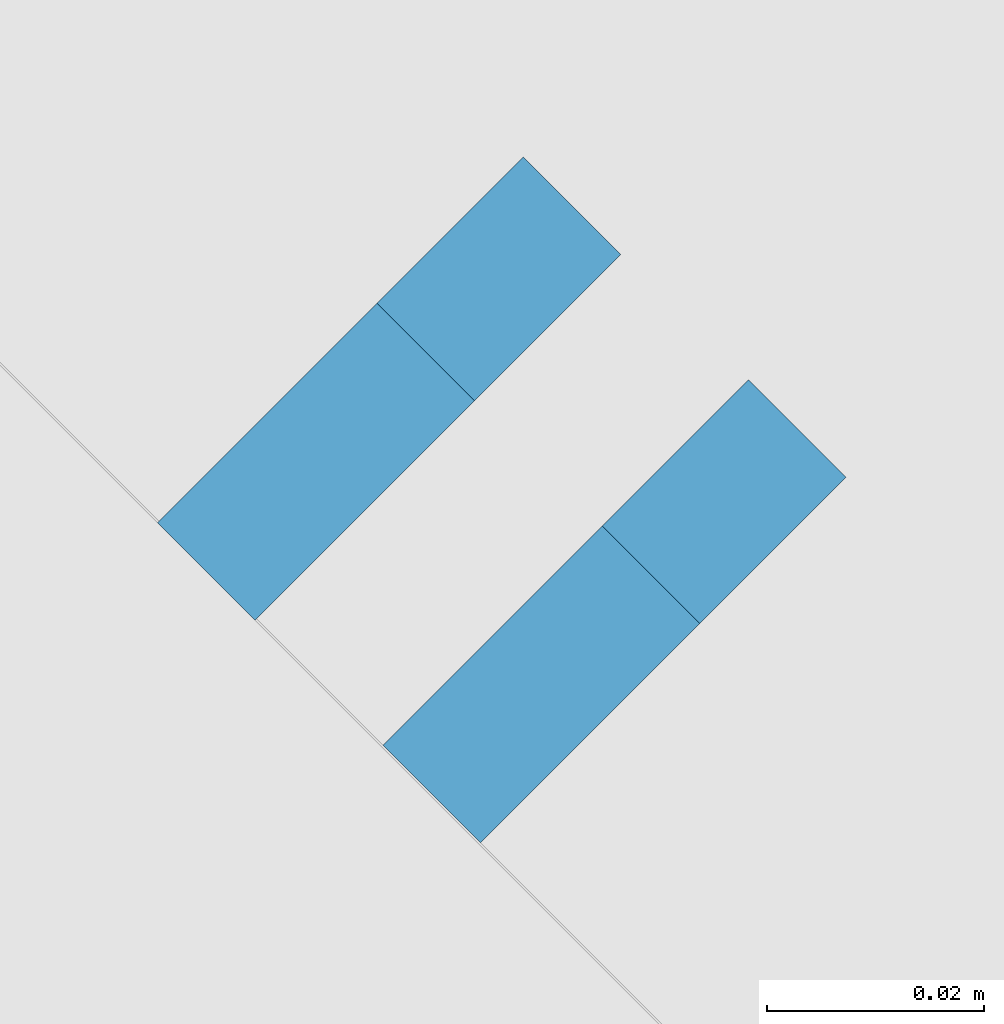
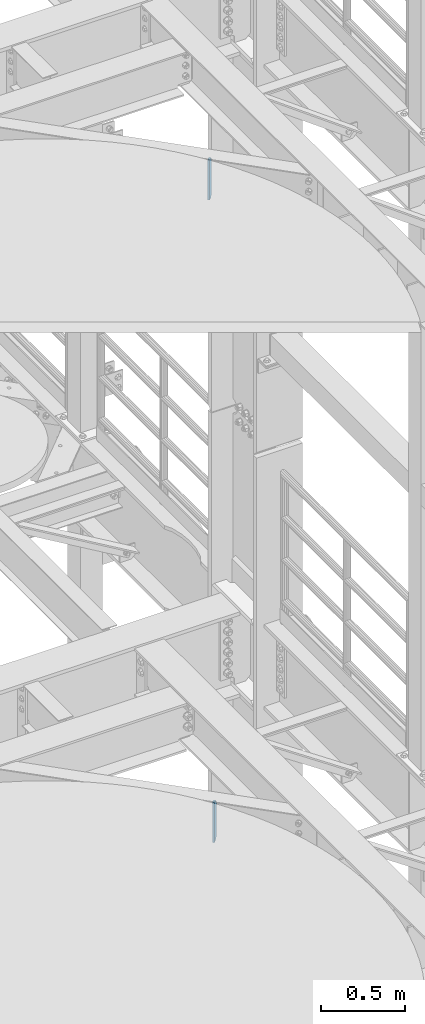
# One storey, part 1568 of 1876: 2 plates, 2 elements without a shape of their own.
"""IFC2X3 building model written with IfcOpenShell, lengths in millimetres."""

from ifc_helpers import new_model, si_unit, frame, origin_with_axes, place, context, subcontext, project, spatial, faceted_brep, material, type_object, element, aggregate, save


model = new_model("IFC2X3")

# Units and contexts
model_context = context("Model", 3, precision=1e-05, world=origin_with_axes())
body_context = subcontext(model_context, "Body", "Model", "MODEL_VIEW")
ifc_project = project(units=[si_unit("LENGTHUNIT", "METRE", prefix="MILLI"), si_unit("AREAUNIT", "SQUARE_METRE"), si_unit("VOLUMEUNIT", "CUBIC_METRE"), si_unit("MASSUNIT", "GRAM", prefix="KILO"), si_unit("TIMEUNIT", "SECOND"), si_unit("PLANEANGLEUNIT", "RADIAN"), si_unit("SOLIDANGLEUNIT", "STERADIAN"), si_unit("THERMODYNAMICTEMPERATUREUNIT", "DEGREE_CELSIUS"), si_unit("LUMINOUSINTENSITYUNIT", "LUMEN")], contexts=[model_context])

# Site, building, storey
site_placement = place(None, origin_with_axes())
site = spatial("IfcSite", under=ifc_project, at=site_placement, CompositionType="ELEMENT")
building_placement = place(site_placement, origin_with_axes())
building = spatial("IfcBuilding", under=site, at=building_placement, Name="Undefined", CompositionType="ELEMENT")
storey_placement = place(building_placement, origin_with_axes())
storey = spatial("IfcBuildingStorey", under=building, at=storey_placement, Name="Undefined", CompositionType="ELEMENT", Elevation=0.0)

# Assembly, plate
assembly_1_placement = place(storey_placement, origin_with_axes())
assembly_1 = element("IfcElementAssembly", 1, at=assembly_1_placement, inside=storey, Name="BEAM", AssemblyPlace="NOTDEFINED", PredefinedType="RIGID_FRAME")
ifc_material = material(Name="STEEL/A36")
plate_type = type_object("IfcPlateType", PredefinedType="NOTDEFINED")
plate_1_placement = place(assembly_1_placement, frame((6301.28054878455, -201.180674335236, 17684.75), z_axis=(0.0, 0.0, 1.0), x_axis=(0.707106781186548, 0.707106781186547, 0.0)))
plate_1 = element("IfcPlate", 2, at=plate_1_placement, type_object=plate_type, material=ifc_material, Name="PLATE", context=body_context, shape_type="Brep", body=[
    faceted_brep([(0.0, -6.35000000000036, 0.0), (-1.13686837721616e-12, -6.35000000000082, 292.100006103516), (1.13686837721616e-12, 6.35000000000105, 292.100006103516), (0.0, 6.35000000000036, 0.0), (28.5750007629385, -6.35000000000014, 292.100006103516), (28.5750007629406, 6.35000000000173, 292.100006103516), (47.6249999999993, -6.34999999999968, 273.050006866455), (47.6250000000014, 6.35000000000218, 273.050006866455), (47.6249999999993, -6.34999999999968, 19.0499992370605), (47.6250000000014, 6.35000000000218, 19.0499992370605), (28.5750007629385, -6.35000000000014, 0.0), (28.5750007629406, 6.35000000000173, 0.0)], [[[0, 1, 2, 3]], [[1, 4, 5, 2]], [[4, 6, 7, 5]], [[6, 8, 9, 7]], [[8, 10, 11, 9]], [[10, 0, 3, 11]], [[5, 7, 9, 11, 3, 2]], [[10, 8, 6, 4, 1, 0]]]),
])
aggregate(assembly_1, [plate_1])

assembly_2_placement = place(storey_placement, origin_with_axes())
assembly_2 = element("IfcElementAssembly", 3, at=assembly_2_placement, inside=storey, Name="BEAM", AssemblyPlace="NOTDEFINED", PredefinedType="RIGID_FRAME")
plate_2_placement = place(assembly_2_placement, frame((6322.0458182018, -221.690383706047, 13011.15), z_axis=(0.0, 0.0, 1.0), x_axis=(0.707106781186548, 0.707106781186547, 0.0)))
plate_2 = element("IfcPlate", 4, at=plate_2_placement, type_object=plate_type, material=ifc_material, Name="PLATE", context=body_context, shape_type="Brep", body=[
    faceted_brep([(0.0, -6.35000000000036, 0.0), (-1.13686837721616e-12, -6.35000000000082, 292.100006103516), (1.13686837721616e-12, 6.35000000000105, 292.100006103516), (0.0, 6.35000000000036, 0.0), (28.5750007629385, -6.35000000000014, 292.100006103516), (28.5750007629406, 6.35000000000173, 292.100006103516), (47.6249999999941, -6.35000000000491, 266.700006484985), (47.6249999999939, 6.34999999999445, 266.700006484985), (47.6249999999993, -6.34999999999968, 19.0499992370605), (47.6250000000014, 6.35000000000218, 19.0499992370605), (28.5750007629385, -6.35000000000014, 0.0), (28.5750007629406, 6.35000000000173, 0.0)], [[[0, 1, 2, 3]], [[1, 4, 5, 2]], [[4, 6, 7, 5]], [[6, 8, 9, 7]], [[8, 10, 11, 9]], [[10, 0, 3, 11]], [[5, 7, 9, 11, 3, 2]], [[10, 8, 6, 4, 1, 0]]]),
])
aggregate(assembly_2, [plate_2])

save(model, "model.ifc")
